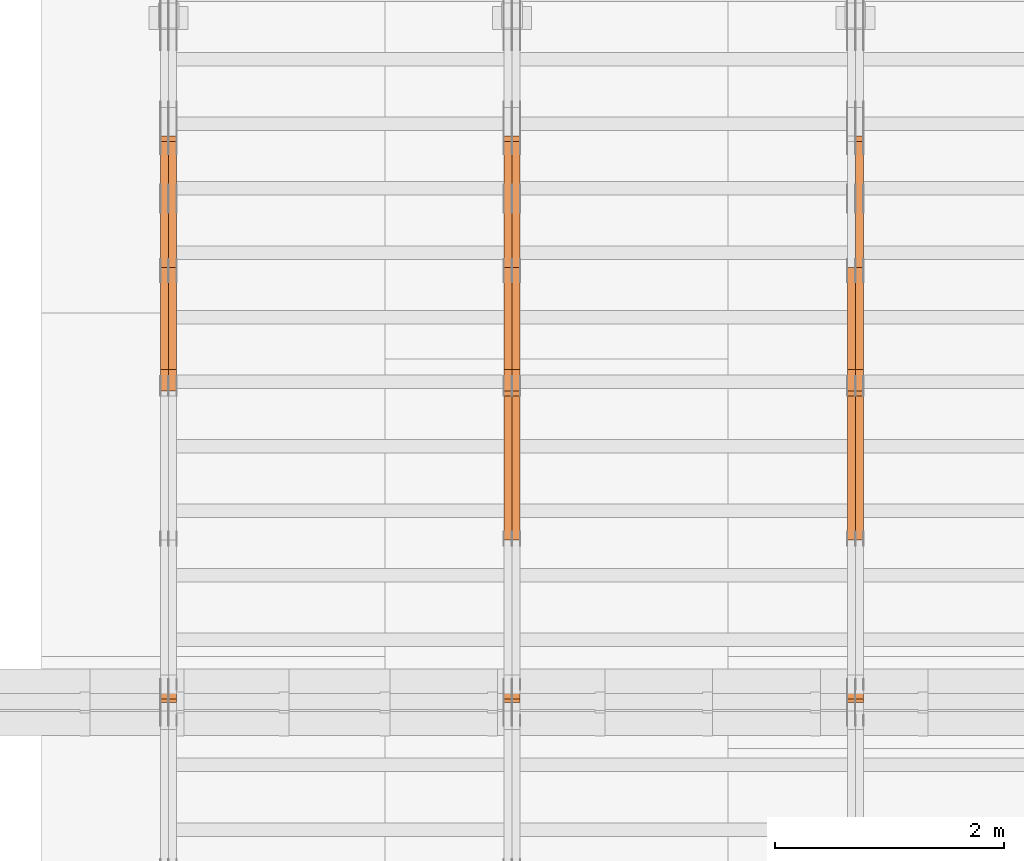
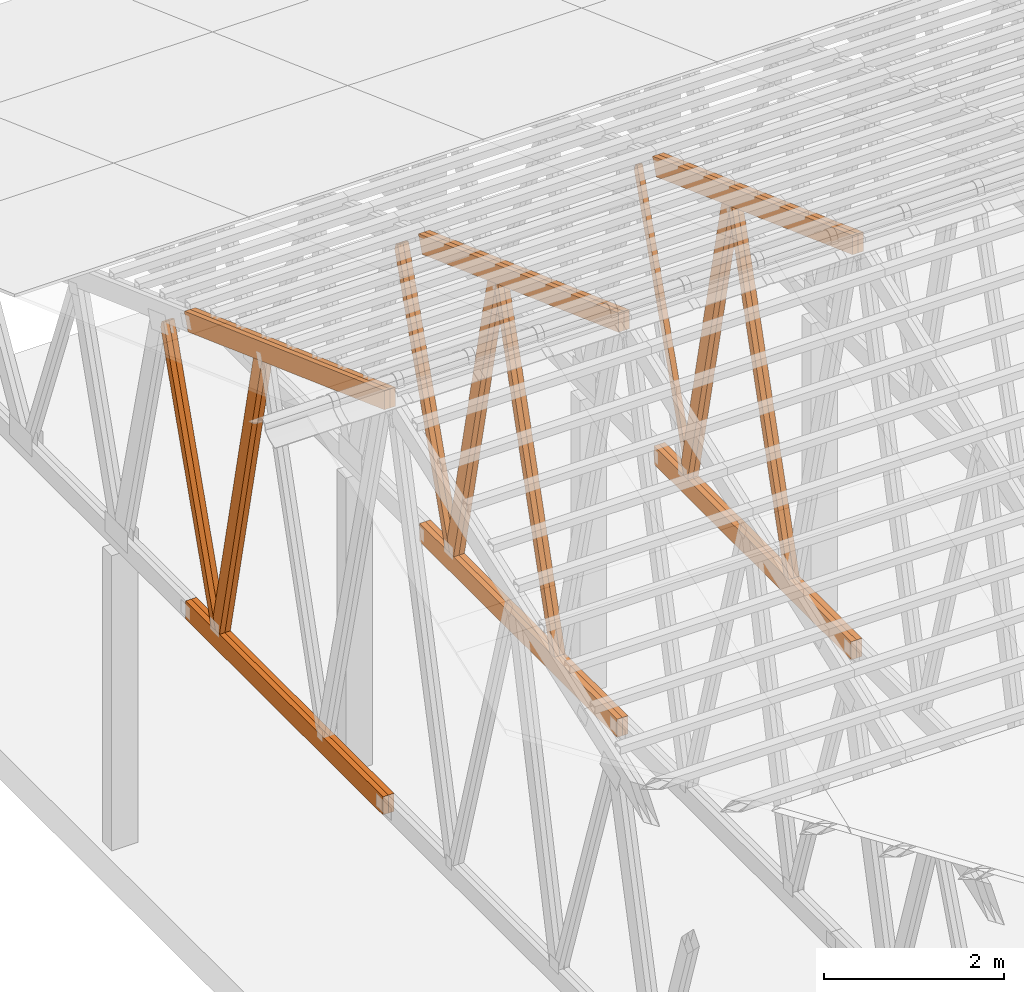
# One storey, part 31 of 189: 27 proxies.
"""IFC2X3 building model written with IfcOpenShell, lengths in millimetres."""

from ifc_helpers import new_model, entity, si_unit, converted_unit, derived_unit, direction, frame, origin, origin_2d_with_axis, place, context, subcontext, project, spatial, polyline, rectangle, outline, extrude, source, transform, mapped, material, type_object, type_shapes, element, save


model = new_model("IFC2X3")

# Units and contexts
model_context = context("Model", 3, precision=0.01, world=origin(), true_north=direction((6.12303176911189e-17, 1.0)))
body_context = subcontext(model_context, "Body", "Model", "MODEL_VIEW")
ifc_project = project(units=[si_unit("LENGTHUNIT", "METRE", prefix="MILLI"), si_unit("AREAUNIT", "SQUARE_METRE"), si_unit("VOLUMEUNIT", "CUBIC_METRE"), converted_unit("PLANEANGLEUNIT", "DEGREE", entity("IfcRatioMeasure", 0.0174532925199433), si_unit("PLANEANGLEUNIT", "RADIAN"), dimensions=[0, 0, 0, 0, 0, 0, 0]), si_unit("MASSUNIT", "GRAM", prefix="KILO"), derived_unit("MASSDENSITYUNIT", [(si_unit("MASSUNIT", "GRAM", prefix="KILO"), 1), (si_unit("LENGTHUNIT", "METRE"), -3)]), si_unit("TIMEUNIT", "SECOND"), si_unit("FREQUENCYUNIT", "HERTZ"), si_unit("THERMODYNAMICTEMPERATUREUNIT", "DEGREE_CELSIUS"), derived_unit("THERMALTRANSMITTANCEUNIT", [(si_unit("MASSUNIT", "GRAM", prefix="KILO"), 1), (si_unit("THERMODYNAMICTEMPERATUREUNIT", "KELVIN"), -1), (si_unit("TIMEUNIT", "SECOND"), -3)]), derived_unit("VOLUMETRICFLOWRATEUNIT", [(si_unit("LENGTHUNIT", "METRE"), 3), (si_unit("TIMEUNIT", "SECOND"), -1)]), si_unit("ELECTRICCURRENTUNIT", "AMPERE"), si_unit("ELECTRICVOLTAGEUNIT", "VOLT"), si_unit("POWERUNIT", "WATT"), si_unit("FORCEUNIT", "NEWTON"), si_unit("ILLUMINANCEUNIT", "LUX"), si_unit("LUMINOUSFLUXUNIT", "LUMEN"), si_unit("LUMINOUSINTENSITYUNIT", "CANDELA"), derived_unit("USERDEFINED", [(si_unit("MASSUNIT", "GRAM", prefix="KILO"), -1), (si_unit("LENGTHUNIT", "METRE"), -2), (si_unit("TIMEUNIT", "SECOND"), 3), (si_unit("LUMINOUSFLUXUNIT", "LUMEN"), 1)]), derived_unit("LINEARVELOCITYUNIT", [(si_unit("LENGTHUNIT", "METRE"), 1), (si_unit("TIMEUNIT", "SECOND"), -1)]), si_unit("PRESSUREUNIT", "PASCAL"), derived_unit("USERDEFINED", [(si_unit("LENGTHUNIT", "METRE"), -2), (si_unit("MASSUNIT", "GRAM", prefix="KILO"), 1), (si_unit("TIMEUNIT", "SECOND"), -2)])], contexts=[model_context])

# Site, building, storey
site_placement = place(None, origin())
site = spatial("IfcSite", under=ifc_project, at=site_placement, CompositionType="ELEMENT")
building_placement = place(site_placement, origin())
building = spatial("IfcBuilding", under=site, at=building_placement, CompositionType="ELEMENT")
storey_placement = place(building_placement, origin())
storey = spatial("IfcBuildingStorey", under=building, at=storey_placement, Name="Default", CompositionType="ELEMENT", Elevation=0.0)

# Proxies
ifc_material_1 = material(Name="IfcSurfaceStyle #36658")
building_element_proxy_type_1 = type_object("IfcBuildingElementProxyType", Name="T1-W6 36656", PredefinedType="NOTDEFINED", material=ifc_material_1)
shared_shape_1 = source(origin(), body_context, "Body", "SweptSolid", [
    extrude(outline(polyline([(-2668.68989660745, -47.5002238228721), (1800.72567700045, -47.5002238228721), (1797.68490303083, 0.000158637170537834), (1711.12272493628, 47.5001445042868), (-2640.84340836012, 47.5001445042868), (-2668.68989660745, -47.5002238228721)])), frame((1800.7257704503, 47.5001445042868, 0.0), z_axis=(0.0, 0.0, 1.0), x_axis=(-1.0, 0.0, 0.0)), (0.0, 0.0, 1.0), 69.9999999999997),
])
type_shapes(building_element_proxy_type_1, [shared_shape_1])
proxy_1_placement = place(building_placement, frame((6335.0, 17516.8749791841, 4507.23620831254), z_axis=(-1.0, 0.0, 0.0), x_axis=(0.0, -0.281285983104611, -0.959623986626466)))
element("IfcBuildingElementProxy", 1, at=proxy_1_placement, inside=storey, type_object=building_element_proxy_type_1, material=ifc_material_1, Name="T1-W6", context=body_context, shape_type="MappedRepresentation", body=[
    mapped(shared_shape_1, transform((0.0, 0.0, 0.0), scale=1.0)),
])
ifc_material_2 = material(Name="IfcSurfaceStyle #36592")
building_element_proxy_type_2 = type_object("IfcBuildingElementProxyType", Name="T1-W6 36590", PredefinedType="NOTDEFINED", material=ifc_material_2)
shared_shape_2 = source(origin(), body_context, "Body", "SweptSolid", [
    extrude(outline(polyline([(-2668.68989660745, -47.5002238228721), (1800.72567700045, -47.5002238228721), (1797.68490303083, 0.000158637170537834), (1711.12272493628, 47.5001445042868), (-2640.84340836012, 47.5001445042868), (-2668.68989660745, -47.5002238228721)])), frame((1800.7257704503, 47.5001445042868, 0.0), z_axis=(0.0, 0.0, 1.0), x_axis=(-1.0, 0.0, 0.0)), (0.0, 0.0, 1.0), 69.9999999999997),
])
type_shapes(building_element_proxy_type_2, [shared_shape_2])
proxy_2_placement = place(building_placement, frame((6265.0, 17516.8749791841, 4507.23620831254), z_axis=(-1.0, 0.0, 0.0), x_axis=(0.0, -0.281285983104611, -0.959623986626466)))
element("IfcBuildingElementProxy", 2, at=proxy_2_placement, inside=storey, type_object=building_element_proxy_type_2, material=ifc_material_2, Name="T1-W6", context=body_context, shape_type="MappedRepresentation", body=[
    mapped(shared_shape_2, transform((0.0, 0.0, 0.0), scale=1.0)),
])
ifc_material_3 = material(Name="IfcSurfaceStyle #36394")
building_element_proxy_type_3 = type_object("IfcBuildingElementProxyType", Name="T1-W3 36392", PredefinedType="NOTDEFINED", material=ifc_material_3)
shared_shape_3 = source(origin(), body_context, "Body", "SweptSolid", [
    extrude(outline(polyline([(-2517.58938959787, -85.0001104675026), (1625.445846867, -85.0001104675027), (1768.20563426494, 0.000209440697654673), (1749.48871563991, 85.0000057471538), (-2625.55080717397, 85.0000057471538), (-2517.58938959787, -85.0001104675026)])), frame((1768.2056683344, 85.0000547211315, 0.0), z_axis=(0.0, 0.0, 1.0), x_axis=(-1.0, 0.0, 0.0)), (0.0, 0.0, 1.0), 69.9999999999997),
])
type_shapes(building_element_proxy_type_3, [shared_shape_3])
proxy_3_placement = place(building_placement, frame((6335.0, 18415.3042863408, 226.720947016584), z_axis=(-1.0, 0.0, 0.0), x_axis=(0.0, -0.215047682154604, 0.976603550269982)))
element("IfcBuildingElementProxy", 3, at=proxy_3_placement, inside=storey, type_object=building_element_proxy_type_3, material=ifc_material_3, Name="T1-W3", context=body_context, shape_type="MappedRepresentation", body=[
    mapped(shared_shape_3, transform((0.0, 0.0, 0.0), scale=1.0)),
])
ifc_material_4 = material(Name="IfcSurfaceStyle #36328")
building_element_proxy_type_4 = type_object("IfcBuildingElementProxyType", Name="T1-W3 36326", PredefinedType="NOTDEFINED", material=ifc_material_4)
shared_shape_4 = source(origin(), body_context, "Body", "SweptSolid", [
    extrude(outline(polyline([(-2517.58938959787, -85.0001104675026), (1625.445846867, -85.0001104675027), (1768.20563426494, 0.000209440697654673), (1749.48871563991, 85.0000057471538), (-2625.55080717397, 85.0000057471538), (-2517.58938959787, -85.0001104675026)])), frame((1768.2056683344, 85.0000547211315, 0.0), z_axis=(0.0, 0.0, 1.0), x_axis=(-1.0, 0.0, 0.0)), (0.0, 0.0, 1.0), 69.9999999999997),
])
type_shapes(building_element_proxy_type_4, [shared_shape_4])
proxy_4_placement = place(building_placement, frame((6265.0, 18415.3042863408, 226.720947016584), z_axis=(-1.0, 0.0, 0.0), x_axis=(0.0, -0.215047682154604, 0.976603550269982)))
element("IfcBuildingElementProxy", 4, at=proxy_4_placement, inside=storey, type_object=building_element_proxy_type_4, material=ifc_material_4, Name="T1-W3", context=body_context, shape_type="MappedRepresentation", body=[
    mapped(shared_shape_4, transform((0.0, 0.0, 0.0), scale=1.0)),
])
ifc_material_5 = material(Name="IfcSurfaceStyle #36130")
building_element_proxy_type_5 = type_object("IfcBuildingElementProxyType", Name="T1-W7 36128", PredefinedType="NOTDEFINED", material=ifc_material_5)
shared_shape_5 = source(origin(), body_context, "Body", "SweptSolid", [
    extrude(outline(polyline([(-2189.6662270939, -47.5000140805343), (1475.30081553583, -47.5000140805343), (1473.93388518462, 0.00042343352179337), (1398.58463533215, 47.4998023637734), (-2158.15310895869, 47.4998023637734), (-2189.6662270939, -47.5000140805343)])), frame((1475.30081553583, 47.5004895824757, 0.0), z_axis=(0.0, 0.0, 1.0), x_axis=(-1.0, 0.0, 0.0)), (0.0, 0.0, 1.0), 69.9999999999998),
])
type_shapes(building_element_proxy_type_5, [shared_shape_5])
proxy_5_placement = place(building_placement, frame((6335.0, 19742.3819153401, 3693.66743808885), z_axis=(-1.0, 0.0, 0.0), x_axis=(0.0, -0.314845237923104, -0.949143021971475)))
element("IfcBuildingElementProxy", 5, at=proxy_5_placement, inside=storey, type_object=building_element_proxy_type_5, material=ifc_material_5, Name="T1-W7", context=body_context, shape_type="MappedRepresentation", body=[
    mapped(shared_shape_5, transform((0.0, 0.0, 0.0), scale=1.0)),
])
ifc_material_6 = material(Name="IfcSurfaceStyle #32884")
building_element_proxy_type_6 = type_object("IfcBuildingElementProxyType", Name="T1-B5 32882", PredefinedType="NOTDEFINED", material=ifc_material_6)
shared_shape_6 = source(origin(), body_context, "Body", "SweptSolid", [
    extrude(rectangle(XDim=4381.5, YDim=245.000000000001, at=origin_2d_with_axis()), frame((2190.75, 122.5, 0.0), z_axis=(0.0, 0.0, 1.0), x_axis=(-1.0, 0.0, 0.0)), (0.0, 0.0, 1.0), 69.9999999999997),
])
type_shapes(building_element_proxy_type_6, [shared_shape_6])
proxy_6_placement = place(building_placement, frame((6335.0, 14780.2587890625, 245.0), z_axis=(-1.0, 0.0, 0.0), x_axis=(0.0, 1.0, 0.0)))
element("IfcBuildingElementProxy", 6, at=proxy_6_placement, inside=storey, type_object=building_element_proxy_type_6, material=ifc_material_6, Name="T1-B5", context=body_context, shape_type="MappedRepresentation", body=[
    mapped(shared_shape_6, transform((0.0, 0.0, 0.0), scale=1.0)),
])
ifc_material_7 = material(Name="IfcSurfaceStyle #32827")
building_element_proxy_type_7 = type_object("IfcBuildingElementProxyType", Name="T1-B5 32825", PredefinedType="NOTDEFINED", material=ifc_material_7)
shared_shape_7 = source(origin(), body_context, "Body", "SweptSolid", [
    extrude(rectangle(XDim=4381.5, YDim=245.000000000001, at=origin_2d_with_axis()), frame((2190.75, 122.5, 0.0), z_axis=(0.0, 0.0, 1.0), x_axis=(-1.0, 0.0, 0.0)), (0.0, 0.0, 1.0), 69.9999999999997),
])
type_shapes(building_element_proxy_type_7, [shared_shape_7])
proxy_7_placement = place(building_placement, frame((6265.0, 14780.2587890625, 245.0), z_axis=(-1.0, 0.0, 0.0), x_axis=(0.0, 1.0, 0.0)))
element("IfcBuildingElementProxy", 7, at=proxy_7_placement, inside=storey, type_object=building_element_proxy_type_7, material=ifc_material_7, Name="T1-B5", context=body_context, shape_type="MappedRepresentation", body=[
    mapped(shared_shape_7, transform((0.0, 0.0, 0.0), scale=1.0)),
])
ifc_material_8 = material(Name="IfcSurfaceStyle #32068")
building_element_proxy_type_8 = type_object("IfcBuildingElementProxyType", Name="T1-T3 32066", PredefinedType="NOTDEFINED", material=ifc_material_8)
shared_shape_8 = source(origin(), body_context, "Body", "SweptSolid", [
    extrude(outline(polyline([(-2386.23525922045, -122.500022994835), (2341.64890001386, -122.500022994835), (2341.64888416412, 122.500022994835), (-2297.06252495753, 122.500022994835), (-2386.23525922045, -122.500022994835)])), frame((2341.64890001386, 122.500051926629, 0.0), z_axis=(0.0, 0.0, 1.0), x_axis=(-1.0, 0.0, 0.0)), (0.0, 0.0, 1.0), 69.9999999999997),
])
type_shapes(building_element_proxy_type_8, [shared_shape_8])
proxy_8_placement = place(building_placement, frame((6335.0, 19108.9628956236, 3921.30465489208), z_axis=(-1.0, 0.0, 0.0), x_axis=(0.0, -0.939692620785908, 0.342020143325669)))
element("IfcBuildingElementProxy", 8, at=proxy_8_placement, inside=storey, type_object=building_element_proxy_type_8, material=ifc_material_8, Name="T1-T3", context=body_context, shape_type="MappedRepresentation", body=[
    mapped(shared_shape_8, transform((0.0, 0.0, 0.0), scale=1.0)),
])
ifc_material_9 = material(Name="IfcSurfaceStyle #32011")
building_element_proxy_type_9 = type_object("IfcBuildingElementProxyType", Name="T1-T3 32009", PredefinedType="NOTDEFINED", material=ifc_material_9)
shared_shape_9 = source(origin(), body_context, "Body", "SweptSolid", [
    extrude(outline(polyline([(-2386.23525922045, -122.500022994835), (2341.64890001386, -122.500022994835), (2341.64888416412, 122.500022994835), (-2297.06252495753, 122.500022994835), (-2386.23525922045, -122.500022994835)])), frame((2341.64890001386, 122.500051926629, 0.0), z_axis=(0.0, 0.0, 1.0), x_axis=(-1.0, 0.0, 0.0)), (0.0, 0.0, 1.0), 69.9999999999997),
])
type_shapes(building_element_proxy_type_9, [shared_shape_9])
proxy_9_placement = place(building_placement, frame((6265.0, 19108.9628956236, 3921.30465489208), z_axis=(-1.0, 0.0, 0.0), x_axis=(0.0, -0.939692620785908, 0.342020143325669)))
element("IfcBuildingElementProxy", 9, at=proxy_9_placement, inside=storey, type_object=building_element_proxy_type_9, material=ifc_material_9, Name="T1-T3", context=body_context, shape_type="MappedRepresentation", body=[
    mapped(shared_shape_9, transform((0.0, 0.0, 0.0), scale=1.0)),
])
ifc_material_10 = material(Name="IfcSurfaceStyle #20868")
building_element_proxy_type_10 = type_object("IfcBuildingElementProxyType", Name="T1-W6 20866", PredefinedType="NOTDEFINED", material=ifc_material_10)
shared_shape_10 = source(origin(), body_context, "Body", "SweptSolid", [
    extrude(outline(polyline([(-2668.68989660745, -47.5002238228721), (1800.72567700045, -47.5002238228721), (1797.68490303083, 0.000158637170537834), (1711.12272493628, 47.5001445042868), (-2640.84340836012, 47.5001445042868), (-2668.68989660745, -47.5002238228721)])), frame((1800.7257704503, 47.5001445042868, 0.0), z_axis=(0.0, 0.0, 1.0), x_axis=(-1.0, 0.0, 0.0)), (0.0, 0.0, 1.0), 69.9999999999997),
])
type_shapes(building_element_proxy_type_10, [shared_shape_10])
proxy_10_placement = place(building_placement, frame((3335.0, 17516.8749791841, 4507.23620831254), z_axis=(-1.0, 0.0, 0.0), x_axis=(0.0, -0.281285983104611, -0.959623986626466)))
element("IfcBuildingElementProxy", 10, at=proxy_10_placement, inside=storey, type_object=building_element_proxy_type_10, material=ifc_material_10, Name="T1-W6", context=body_context, shape_type="MappedRepresentation", body=[
    mapped(shared_shape_10, transform((0.0, 0.0, 0.0), scale=1.0)),
])
ifc_material_11 = material(Name="IfcSurfaceStyle #20802")
building_element_proxy_type_11 = type_object("IfcBuildingElementProxyType", Name="T1-W6 20800", PredefinedType="NOTDEFINED", material=ifc_material_11)
shared_shape_11 = source(origin(), body_context, "Body", "SweptSolid", [
    extrude(outline(polyline([(-2668.68989660745, -47.5002238228721), (1800.72567700045, -47.5002238228721), (1797.68490303083, 0.000158637170537834), (1711.12272493628, 47.5001445042868), (-2640.84340836012, 47.5001445042868), (-2668.68989660745, -47.5002238228721)])), frame((1800.7257704503, 47.5001445042868, 0.0), z_axis=(0.0, 0.0, 1.0), x_axis=(-1.0, 0.0, 0.0)), (0.0, 0.0, 1.0), 69.9999999999997),
])
type_shapes(building_element_proxy_type_11, [shared_shape_11])
proxy_11_placement = place(building_placement, frame((3265.0, 17516.8749791841, 4507.23620831254), z_axis=(-1.0, 0.0, 0.0), x_axis=(0.0, -0.281285983104611, -0.959623986626466)))
element("IfcBuildingElementProxy", 11, at=proxy_11_placement, inside=storey, type_object=building_element_proxy_type_11, material=ifc_material_11, Name="T1-W6", context=body_context, shape_type="MappedRepresentation", body=[
    mapped(shared_shape_11, transform((0.0, 0.0, 0.0), scale=1.0)),
])
ifc_material_12 = material(Name="IfcSurfaceStyle #20604")
building_element_proxy_type_12 = type_object("IfcBuildingElementProxyType", Name="T1-W3 20602", PredefinedType="NOTDEFINED", material=ifc_material_12)
shared_shape_12 = source(origin(), body_context, "Body", "SweptSolid", [
    extrude(outline(polyline([(-2517.58938959787, -85.0001104675026), (1625.445846867, -85.0001104675027), (1768.20563426494, 0.000209440697654673), (1749.48871563991, 85.0000057471538), (-2625.55080717397, 85.0000057471538), (-2517.58938959787, -85.0001104675026)])), frame((1768.2056683344, 85.0000547211315, 0.0), z_axis=(0.0, 0.0, 1.0), x_axis=(-1.0, 0.0, 0.0)), (0.0, 0.0, 1.0), 69.9999999999997),
])
type_shapes(building_element_proxy_type_12, [shared_shape_12])
proxy_12_placement = place(building_placement, frame((3335.0, 18415.3042863408, 226.720947016584), z_axis=(-1.0, 0.0, 0.0), x_axis=(0.0, -0.215047682154604, 0.976603550269982)))
element("IfcBuildingElementProxy", 12, at=proxy_12_placement, inside=storey, type_object=building_element_proxy_type_12, material=ifc_material_12, Name="T1-W3", context=body_context, shape_type="MappedRepresentation", body=[
    mapped(shared_shape_12, transform((0.0, 0.0, 0.0), scale=1.0)),
])
ifc_material_13 = material(Name="IfcSurfaceStyle #20538")
building_element_proxy_type_13 = type_object("IfcBuildingElementProxyType", Name="T1-W3 20536", PredefinedType="NOTDEFINED", material=ifc_material_13)
shared_shape_13 = source(origin(), body_context, "Body", "SweptSolid", [
    extrude(outline(polyline([(-2517.58938959787, -85.0001104675026), (1625.445846867, -85.0001104675027), (1768.20563426494, 0.000209440697654673), (1749.48871563991, 85.0000057471538), (-2625.55080717397, 85.0000057471538), (-2517.58938959787, -85.0001104675026)])), frame((1768.2056683344, 85.0000547211315, 0.0), z_axis=(0.0, 0.0, 1.0), x_axis=(-1.0, 0.0, 0.0)), (0.0, 0.0, 1.0), 69.9999999999997),
])
type_shapes(building_element_proxy_type_13, [shared_shape_13])
proxy_13_placement = place(building_placement, frame((3265.0, 18415.3042863408, 226.720947016584), z_axis=(-1.0, 0.0, 0.0), x_axis=(0.0, -0.215047682154604, 0.976603550269982)))
element("IfcBuildingElementProxy", 13, at=proxy_13_placement, inside=storey, type_object=building_element_proxy_type_13, material=ifc_material_13, Name="T1-W3", context=body_context, shape_type="MappedRepresentation", body=[
    mapped(shared_shape_13, transform((0.0, 0.0, 0.0), scale=1.0)),
])
ifc_material_14 = material(Name="IfcSurfaceStyle #20340")
building_element_proxy_type_14 = type_object("IfcBuildingElementProxyType", Name="T1-W7 20338", PredefinedType="NOTDEFINED", material=ifc_material_14)
shared_shape_14 = source(origin(), body_context, "Body", "SweptSolid", [
    extrude(outline(polyline([(-2189.6662270939, -47.5000140805343), (1475.30081553583, -47.5000140805343), (1473.93388518462, 0.00042343352179337), (1398.58463533215, 47.4998023637734), (-2158.15310895869, 47.4998023637734), (-2189.6662270939, -47.5000140805343)])), frame((1475.30081553583, 47.5004895824757, 0.0), z_axis=(0.0, 0.0, 1.0), x_axis=(-1.0, 0.0, 0.0)), (0.0, 0.0, 1.0), 69.9999999999998),
])
type_shapes(building_element_proxy_type_14, [shared_shape_14])
proxy_14_placement = place(building_placement, frame((3335.0, 19742.3819153401, 3693.66743808885), z_axis=(-1.0, 0.0, 0.0), x_axis=(0.0, -0.314845237923104, -0.949143021971475)))
element("IfcBuildingElementProxy", 14, at=proxy_14_placement, inside=storey, type_object=building_element_proxy_type_14, material=ifc_material_14, Name="T1-W7", context=body_context, shape_type="MappedRepresentation", body=[
    mapped(shared_shape_14, transform((0.0, 0.0, 0.0), scale=1.0)),
])
ifc_material_15 = material(Name="IfcSurfaceStyle #20274")
building_element_proxy_type_15 = type_object("IfcBuildingElementProxyType", Name="T1-W7 20272", PredefinedType="NOTDEFINED", material=ifc_material_15)
shared_shape_15 = source(origin(), body_context, "Body", "SweptSolid", [
    extrude(outline(polyline([(-2189.6662270939, -47.5000140805343), (1475.30081553583, -47.5000140805343), (1473.93388518462, 0.00042343352179337), (1398.58463533215, 47.4998023637734), (-2158.15310895869, 47.4998023637734), (-2189.6662270939, -47.5000140805343)])), frame((1475.30081553583, 47.5004895824757, 0.0), z_axis=(0.0, 0.0, 1.0), x_axis=(-1.0, 0.0, 0.0)), (0.0, 0.0, 1.0), 69.9999999999998),
])
type_shapes(building_element_proxy_type_15, [shared_shape_15])
proxy_15_placement = place(building_placement, frame((3265.0, 19742.3819153401, 3693.66743808885), z_axis=(-1.0, 0.0, 0.0), x_axis=(0.0, -0.314845237923104, -0.949143021971475)))
element("IfcBuildingElementProxy", 15, at=proxy_15_placement, inside=storey, type_object=building_element_proxy_type_15, material=ifc_material_15, Name="T1-W7", context=body_context, shape_type="MappedRepresentation", body=[
    mapped(shared_shape_15, transform((0.0, 0.0, 0.0), scale=1.0)),
])
ifc_material_16 = material(Name="IfcSurfaceStyle #17094")
building_element_proxy_type_16 = type_object("IfcBuildingElementProxyType", Name="T1-B5 17092", PredefinedType="NOTDEFINED", material=ifc_material_16)
shared_shape_16 = source(origin(), body_context, "Body", "SweptSolid", [
    extrude(rectangle(XDim=4381.5, YDim=245.000000000001, at=origin_2d_with_axis()), frame((2190.75, 122.5, 0.0), z_axis=(0.0, 0.0, 1.0), x_axis=(-1.0, 0.0, 0.0)), (0.0, 0.0, 1.0), 69.9999999999997),
])
type_shapes(building_element_proxy_type_16, [shared_shape_16])
proxy_16_placement = place(building_placement, frame((3335.0, 14780.2587890625, 245.0), z_axis=(-1.0, 0.0, 0.0), x_axis=(0.0, 1.0, 0.0)))
element("IfcBuildingElementProxy", 16, at=proxy_16_placement, inside=storey, type_object=building_element_proxy_type_16, material=ifc_material_16, Name="T1-B5", context=body_context, shape_type="MappedRepresentation", body=[
    mapped(shared_shape_16, transform((0.0, 0.0, 0.0), scale=1.0)),
])
ifc_material_17 = material(Name="IfcSurfaceStyle #17037")
building_element_proxy_type_17 = type_object("IfcBuildingElementProxyType", Name="T1-B5 17035", PredefinedType="NOTDEFINED", material=ifc_material_17)
shared_shape_17 = source(origin(), body_context, "Body", "SweptSolid", [
    extrude(rectangle(XDim=4381.5, YDim=245.000000000001, at=origin_2d_with_axis()), frame((2190.75, 122.5, 0.0), z_axis=(0.0, 0.0, 1.0), x_axis=(-1.0, 0.0, 0.0)), (0.0, 0.0, 1.0), 69.9999999999997),
])
type_shapes(building_element_proxy_type_17, [shared_shape_17])
proxy_17_placement = place(building_placement, frame((3265.0, 14780.2587890625, 245.0), z_axis=(-1.0, 0.0, 0.0), x_axis=(0.0, 1.0, 0.0)))
element("IfcBuildingElementProxy", 17, at=proxy_17_placement, inside=storey, type_object=building_element_proxy_type_17, material=ifc_material_17, Name="T1-B5", context=body_context, shape_type="MappedRepresentation", body=[
    mapped(shared_shape_17, transform((0.0, 0.0, 0.0), scale=1.0)),
])
ifc_material_18 = material(Name="IfcSurfaceStyle #16278")
building_element_proxy_type_18 = type_object("IfcBuildingElementProxyType", Name="T1-T3 16276", PredefinedType="NOTDEFINED", material=ifc_material_18)
shared_shape_18 = source(origin(), body_context, "Body", "SweptSolid", [
    extrude(outline(polyline([(-2386.23525922045, -122.500022994835), (2341.64890001386, -122.500022994835), (2341.64888416412, 122.500022994835), (-2297.06252495753, 122.500022994835), (-2386.23525922045, -122.500022994835)])), frame((2341.64890001386, 122.500051926629, 0.0), z_axis=(0.0, 0.0, 1.0), x_axis=(-1.0, 0.0, 0.0)), (0.0, 0.0, 1.0), 69.9999999999997),
])
type_shapes(building_element_proxy_type_18, [shared_shape_18])
proxy_18_placement = place(building_placement, frame((3335.0, 19108.9628956236, 3921.30465489208), z_axis=(-1.0, 0.0, 0.0), x_axis=(0.0, -0.939692620785908, 0.342020143325669)))
element("IfcBuildingElementProxy", 18, at=proxy_18_placement, inside=storey, type_object=building_element_proxy_type_18, material=ifc_material_18, Name="T1-T3", context=body_context, shape_type="MappedRepresentation", body=[
    mapped(shared_shape_18, transform((0.0, 0.0, 0.0), scale=1.0)),
])
ifc_material_19 = material(Name="IfcSurfaceStyle #16221")
building_element_proxy_type_19 = type_object("IfcBuildingElementProxyType", Name="T1-T3 16219", PredefinedType="NOTDEFINED", material=ifc_material_19)
shared_shape_19 = source(origin(), body_context, "Body", "SweptSolid", [
    extrude(outline(polyline([(-2386.23525922045, -122.500022994835), (2341.64890001386, -122.500022994835), (2341.64888416412, 122.500022994835), (-2297.06252495753, 122.500022994835), (-2386.23525922045, -122.500022994835)])), frame((2341.64890001386, 122.500051926629, 0.0), z_axis=(0.0, 0.0, 1.0), x_axis=(-1.0, 0.0, 0.0)), (0.0, 0.0, 1.0), 69.9999999999997),
])
type_shapes(building_element_proxy_type_19, [shared_shape_19])
proxy_19_placement = place(building_placement, frame((3265.0, 19108.9628956236, 3921.30465489208), z_axis=(-1.0, 0.0, 0.0), x_axis=(0.0, -0.939692620785908, 0.342020143325669)))
element("IfcBuildingElementProxy", 19, at=proxy_19_placement, inside=storey, type_object=building_element_proxy_type_19, material=ifc_material_19, Name="T1-T3", context=body_context, shape_type="MappedRepresentation", body=[
    mapped(shared_shape_19, transform((0.0, 0.0, 0.0), scale=1.0)),
])
ifc_material_20 = material(Name="IfcSurfaceStyle #4811")
building_element_proxy_type_20 = type_object("IfcBuildingElementProxyType", Name="T1-W3 4809", PredefinedType="NOTDEFINED", material=ifc_material_20)
shared_shape_20 = source(origin(), body_context, "Body", "SweptSolid", [
    extrude(outline(polyline([(-2517.58938959787, -85.0001104675026), (1625.445846867, -85.0001104675027), (1768.20563426494, 0.000209440697654673), (1749.48871563991, 85.0000057471538), (-2625.55080717397, 85.0000057471538), (-2517.58938959787, -85.0001104675026)])), frame((1768.2056683344, 85.0000547211315, 0.0), z_axis=(0.0, 0.0, 1.0), x_axis=(-1.0, 0.0, 0.0)), (0.0, 0.0, 1.0), 69.9999999999997),
])
type_shapes(building_element_proxy_type_20, [shared_shape_20])
proxy_20_placement = place(building_placement, frame((335.0, 18415.3042863408, 226.720947016584), z_axis=(-1.0, 0.0, 0.0), x_axis=(0.0, -0.215047682154604, 0.976603550269982)))
element("IfcBuildingElementProxy", 20, at=proxy_20_placement, inside=storey, type_object=building_element_proxy_type_20, material=ifc_material_20, Name="T1-W3", context=body_context, shape_type="MappedRepresentation", body=[
    mapped(shared_shape_20, transform((0.0, 0.0, 0.0), scale=1.0)),
])
ifc_material_21 = material(Name="IfcSurfaceStyle #4745")
building_element_proxy_type_21 = type_object("IfcBuildingElementProxyType", Name="T1-W3 4743", PredefinedType="NOTDEFINED", material=ifc_material_21)
shared_shape_21 = source(origin(), body_context, "Body", "SweptSolid", [
    extrude(outline(polyline([(-2517.58938959787, -85.0001104675026), (1625.445846867, -85.0001104675027), (1768.20563426494, 0.000209440697654673), (1749.48871563991, 85.0000057471538), (-2625.55080717397, 85.0000057471538), (-2517.58938959787, -85.0001104675026)])), frame((1768.2056683344, 85.0000547211315, 0.0), z_axis=(0.0, 0.0, 1.0), x_axis=(-1.0, 0.0, 0.0)), (0.0, 0.0, 1.0), 69.9999999999997),
])
type_shapes(building_element_proxy_type_21, [shared_shape_21])
proxy_21_placement = place(building_placement, frame((265.0, 18415.3042863408, 226.720947016584), z_axis=(-1.0, 0.0, 0.0), x_axis=(0.0, -0.215047682154604, 0.976603550269982)))
element("IfcBuildingElementProxy", 21, at=proxy_21_placement, inside=storey, type_object=building_element_proxy_type_21, material=ifc_material_21, Name="T1-W3", context=body_context, shape_type="MappedRepresentation", body=[
    mapped(shared_shape_21, transform((0.0, 0.0, 0.0), scale=1.0)),
])
ifc_material_22 = material(Name="IfcSurfaceStyle #4547")
building_element_proxy_type_22 = type_object("IfcBuildingElementProxyType", Name="T1-W7 4545", PredefinedType="NOTDEFINED", material=ifc_material_22)
shared_shape_22 = source(origin(), body_context, "Body", "SweptSolid", [
    extrude(outline(polyline([(-2189.6662270939, -47.5000140805343), (1475.30081553583, -47.5000140805343), (1473.93388518462, 0.00042343352179337), (1398.58463533215, 47.4998023637734), (-2158.15310895869, 47.4998023637734), (-2189.6662270939, -47.5000140805343)])), frame((1475.30081553583, 47.5004895824757, 0.0), z_axis=(0.0, 0.0, 1.0), x_axis=(-1.0, 0.0, 0.0)), (0.0, 0.0, 1.0), 69.9999999999998),
])
type_shapes(building_element_proxy_type_22, [shared_shape_22])
proxy_22_placement = place(building_placement, frame((335.0, 19742.3819153401, 3693.66743808885), z_axis=(-1.0, 0.0, 0.0), x_axis=(0.0, -0.314845237923104, -0.949143021971475)))
element("IfcBuildingElementProxy", 22, at=proxy_22_placement, inside=storey, type_object=building_element_proxy_type_22, material=ifc_material_22, Name="T1-W7", context=body_context, shape_type="MappedRepresentation", body=[
    mapped(shared_shape_22, transform((0.0, 0.0, 0.0), scale=1.0)),
])
ifc_material_23 = material(Name="IfcSurfaceStyle #4481")
building_element_proxy_type_23 = type_object("IfcBuildingElementProxyType", Name="T1-W7 4479", PredefinedType="NOTDEFINED", material=ifc_material_23)
shared_shape_23 = source(origin(), body_context, "Body", "SweptSolid", [
    extrude(outline(polyline([(-2189.6662270939, -47.5000140805343), (1475.30081553583, -47.5000140805343), (1473.93388518462, 0.00042343352179337), (1398.58463533215, 47.4998023637734), (-2158.15310895869, 47.4998023637734), (-2189.6662270939, -47.5000140805343)])), frame((1475.30081553583, 47.5004895824757, 0.0), z_axis=(0.0, 0.0, 1.0), x_axis=(-1.0, 0.0, 0.0)), (0.0, 0.0, 1.0), 69.9999999999998),
])
type_shapes(building_element_proxy_type_23, [shared_shape_23])
proxy_23_placement = place(building_placement, frame((265.0, 19742.3819153401, 3693.66743808885), z_axis=(-1.0, 0.0, 0.0), x_axis=(0.0, -0.314845237923104, -0.949143021971475)))
element("IfcBuildingElementProxy", 23, at=proxy_23_placement, inside=storey, type_object=building_element_proxy_type_23, material=ifc_material_23, Name="T1-W7", context=body_context, shape_type="MappedRepresentation", body=[
    mapped(shared_shape_23, transform((0.0, 0.0, 0.0), scale=1.0)),
])
ifc_material_24 = material(Name="IfcSurfaceStyle #1301")
building_element_proxy_type_24 = type_object("IfcBuildingElementProxyType", Name="T1-B5 1299", PredefinedType="NOTDEFINED", material=ifc_material_24)
shared_shape_24 = source(origin(), body_context, "Body", "SweptSolid", [
    extrude(rectangle(XDim=4381.5, YDim=245.000000000001, at=origin_2d_with_axis()), frame((2190.75, 122.5, 0.0), z_axis=(0.0, 0.0, 1.0), x_axis=(-1.0, 0.0, 0.0)), (0.0, 0.0, 1.0), 69.9999999999997),
])
type_shapes(building_element_proxy_type_24, [shared_shape_24])
proxy_24_placement = place(building_placement, frame((335.0, 14780.2587890625, 245.0), z_axis=(-1.0, 0.0, 0.0), x_axis=(0.0, 1.0, 0.0)))
element("IfcBuildingElementProxy", 24, at=proxy_24_placement, inside=storey, type_object=building_element_proxy_type_24, material=ifc_material_24, Name="T1-B5", context=body_context, shape_type="MappedRepresentation", body=[
    mapped(shared_shape_24, transform((0.0, 0.0, 0.0), scale=1.0)),
])
ifc_material_25 = material(Name="IfcSurfaceStyle #1244")
building_element_proxy_type_25 = type_object("IfcBuildingElementProxyType", Name="T1-B5 1242", PredefinedType="NOTDEFINED", material=ifc_material_25)
shared_shape_25 = source(origin(), body_context, "Body", "SweptSolid", [
    extrude(rectangle(XDim=4381.5, YDim=245.000000000001, at=origin_2d_with_axis()), frame((2190.75, 122.5, 0.0), z_axis=(0.0, 0.0, 1.0), x_axis=(-1.0, 0.0, 0.0)), (0.0, 0.0, 1.0), 69.9999999999997),
])
type_shapes(building_element_proxy_type_25, [shared_shape_25])
proxy_25_placement = place(building_placement, frame((265.0, 14780.2587890625, 245.0), z_axis=(-1.0, 0.0, 0.0), x_axis=(0.0, 1.0, 0.0)))
element("IfcBuildingElementProxy", 25, at=proxy_25_placement, inside=storey, type_object=building_element_proxy_type_25, material=ifc_material_25, Name="T1-B5", context=body_context, shape_type="MappedRepresentation", body=[
    mapped(shared_shape_25, transform((0.0, 0.0, 0.0), scale=1.0)),
])
ifc_material_26 = material(Name="IfcSurfaceStyle #485")
building_element_proxy_type_26 = type_object("IfcBuildingElementProxyType", Name="T1-T3 483", PredefinedType="NOTDEFINED", material=ifc_material_26)
shared_shape_26 = source(origin(), body_context, "Body", "SweptSolid", [
    extrude(outline(polyline([(-2386.23525922045, -122.500022994835), (2341.64890001386, -122.500022994835), (2341.64888416412, 122.500022994835), (-2297.06252495753, 122.500022994835), (-2386.23525922045, -122.500022994835)])), frame((2341.64890001386, 122.500051926629, 0.0), z_axis=(0.0, 0.0, 1.0), x_axis=(-1.0, 0.0, 0.0)), (0.0, 0.0, 1.0), 69.9999999999997),
])
type_shapes(building_element_proxy_type_26, [shared_shape_26])
proxy_26_placement = place(building_placement, frame((335.0, 19108.9628956236, 3921.30465489208), z_axis=(-1.0, 0.0, 0.0), x_axis=(0.0, -0.939692620785908, 0.342020143325669)))
element("IfcBuildingElementProxy", 26, at=proxy_26_placement, inside=storey, type_object=building_element_proxy_type_26, material=ifc_material_26, Name="T1-T3", context=body_context, shape_type="MappedRepresentation", body=[
    mapped(shared_shape_26, transform((0.0, 0.0, 0.0), scale=1.0)),
])
ifc_material_27 = material(Name="IfcSurfaceStyle #428")
building_element_proxy_type_27 = type_object("IfcBuildingElementProxyType", Name="T1-T3 426", PredefinedType="NOTDEFINED", material=ifc_material_27)
shared_shape_27 = source(origin(), body_context, "Body", "SweptSolid", [
    extrude(outline(polyline([(-2386.23525922045, -122.500022994835), (2341.64890001386, -122.500022994835), (2341.64888416412, 122.500022994835), (-2297.06252495753, 122.500022994835), (-2386.23525922045, -122.500022994835)])), frame((2341.64890001386, 122.500051926629, 0.0), z_axis=(0.0, 0.0, 1.0), x_axis=(-1.0, 0.0, 0.0)), (0.0, 0.0, 1.0), 69.9999999999997),
])
type_shapes(building_element_proxy_type_27, [shared_shape_27])
proxy_27_placement = place(building_placement, frame((265.0, 19108.9628956236, 3921.30465489208), z_axis=(-1.0, 0.0, 0.0), x_axis=(0.0, -0.939692620785908, 0.342020143325669)))
element("IfcBuildingElementProxy", 27, at=proxy_27_placement, inside=storey, type_object=building_element_proxy_type_27, material=ifc_material_27, Name="T1-T3", context=body_context, shape_type="MappedRepresentation", body=[
    mapped(shared_shape_27, transform((0.0, 0.0, 0.0), scale=1.0)),
])

save(model, "model.ifc")
